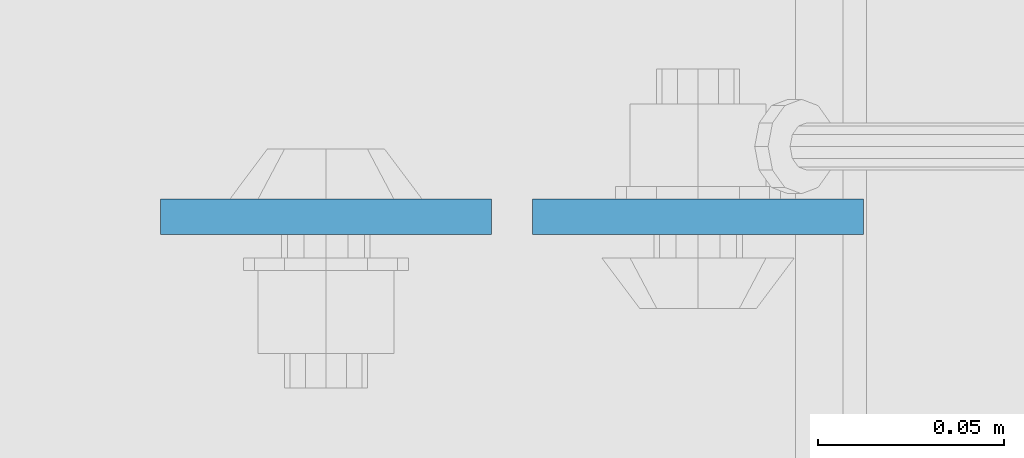
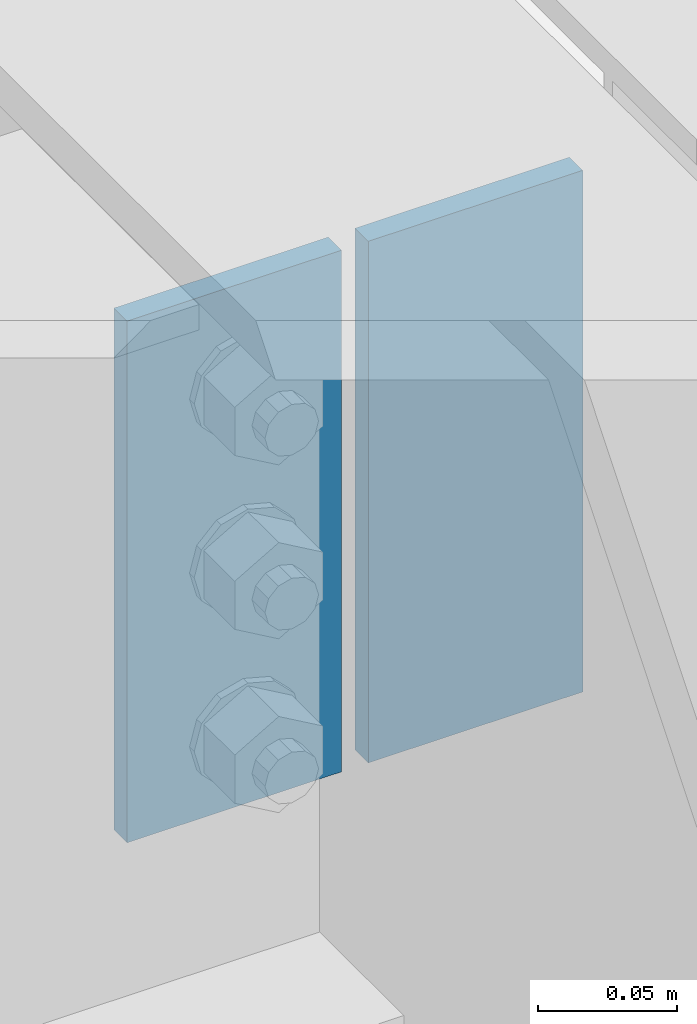
# One storey, part 3165 of 3843: 2 plates, 1 element without a shape of its own.
"""IFC2X3 building model written with IfcOpenShell, lengths in millimetres."""

from ifc_helpers import new_model, si_unit, frame, origin_with_axes, place, context, subcontext, project, spatial, faceted_brep, material, type_object, element, aggregate, save


model = new_model("IFC2X3")

# Units and contexts
model_context = context("Model", 3, precision=1e-05, world=origin_with_axes())
body_context = subcontext(model_context, "Body", "Model", "MODEL_VIEW")
ifc_project = project(units=[si_unit("LENGTHUNIT", "METRE", prefix="MILLI"), si_unit("AREAUNIT", "SQUARE_METRE"), si_unit("VOLUMEUNIT", "CUBIC_METRE"), si_unit("MASSUNIT", "GRAM", prefix="KILO"), si_unit("TIMEUNIT", "SECOND"), si_unit("PLANEANGLEUNIT", "RADIAN"), si_unit("SOLIDANGLEUNIT", "STERADIAN"), si_unit("THERMODYNAMICTEMPERATUREUNIT", "DEGREE_CELSIUS"), si_unit("LUMINOUSINTENSITYUNIT", "LUMEN")], contexts=[model_context])

# Site, building, storey
site_placement = place(None, origin_with_axes())
site = spatial("IfcSite", under=ifc_project, at=site_placement, CompositionType="ELEMENT")
building_placement = place(site_placement, origin_with_axes())
building = spatial("IfcBuilding", under=site, at=building_placement, Name="Undefined", CompositionType="ELEMENT")
storey_placement = place(building_placement, origin_with_axes())
storey = spatial("IfcBuildingStorey", under=building, at=storey_placement, Name="Undefined", CompositionType="ELEMENT", Elevation=0.0)

# Assembly, plates
assembly_placement = place(storey_placement, origin_with_axes())
assembly = element("IfcElementAssembly", 1, at=assembly_placement, inside=storey, Name="BEAM", AssemblyPlace="NOTDEFINED", PredefinedType="RIGID_FRAME")
ifc_material = material(Name="STEEL/A572-50")
plate_type = type_object("IfcPlateType", PredefinedType="NOTDEFINED")
plate_1_placement = place(assembly_placement, frame((62641.95625, 17130.0775, 42418.0), z_axis=(1.0, 0.0, 0.0), x_axis=(0.0, 0.0, -1.0)))
plate_1 = element("IfcPlate", 2, at=plate_1_placement, type_object=plate_type, material=ifc_material, Name="PLATE", context=body_context, shape_type="Brep", body=[
    faceted_brep([(0.0, -4.76249999999709, 0.0), (0.0, -4.76249999999709, 88.9000015258789), (0.0, 4.76249999999709, 88.9000015258789), (0.0, 4.76249999999709, 0.0), (228.600006102781, -4.7625000004191, 88.9000015257589), (228.600006102781, 4.76249999954598, 88.9000015257443), (228.600006103079, -4.7625000004482, 7.27595761418343e-12), (228.600006103079, 4.76249999954598, -7.27595761418343e-12)], [[[0, 1, 2, 3]], [[1, 4, 5, 2]], [[4, 6, 7, 5]], [[6, 0, 3, 7]], [[5, 7, 3, 2]], [[6, 4, 1, 0]]]),
])
plate_2_placement = place(assembly_placement, frame((62630.84375, 17130.0775, 42418.0), z_axis=(-1.0, 0.0, 0.0), x_axis=(0.0, 0.0, -1.0)))
plate_2 = element("IfcPlate", 3, at=plate_2_placement, type_object=plate_type, material=ifc_material, Name="PLATE", context=body_context, shape_type="Brep", body=[
    faceted_brep([(0.0, -4.76249999999709, 0.0), (0.0, -4.76249999999709, 88.9000015258789), (0.0, 4.76249999999709, 88.9000015258789), (0.0, 4.76249999999709, 0.0), (228.600006102781, -4.7625000004191, 88.9000015257589), (228.600006102781, 4.76249999954598, 88.9000015257443), (228.600006103079, -4.7625000004482, 7.27595761418343e-12), (228.600006103079, 4.76249999954598, -7.27595761418343e-12)], [[[0, 1, 2, 3]], [[1, 4, 5, 2]], [[4, 6, 7, 5]], [[6, 0, 3, 7]], [[5, 7, 3, 2]], [[6, 4, 1, 0]]]),
])
aggregate(assembly, [plate_1, plate_2])

save(model, "model.ifc")
